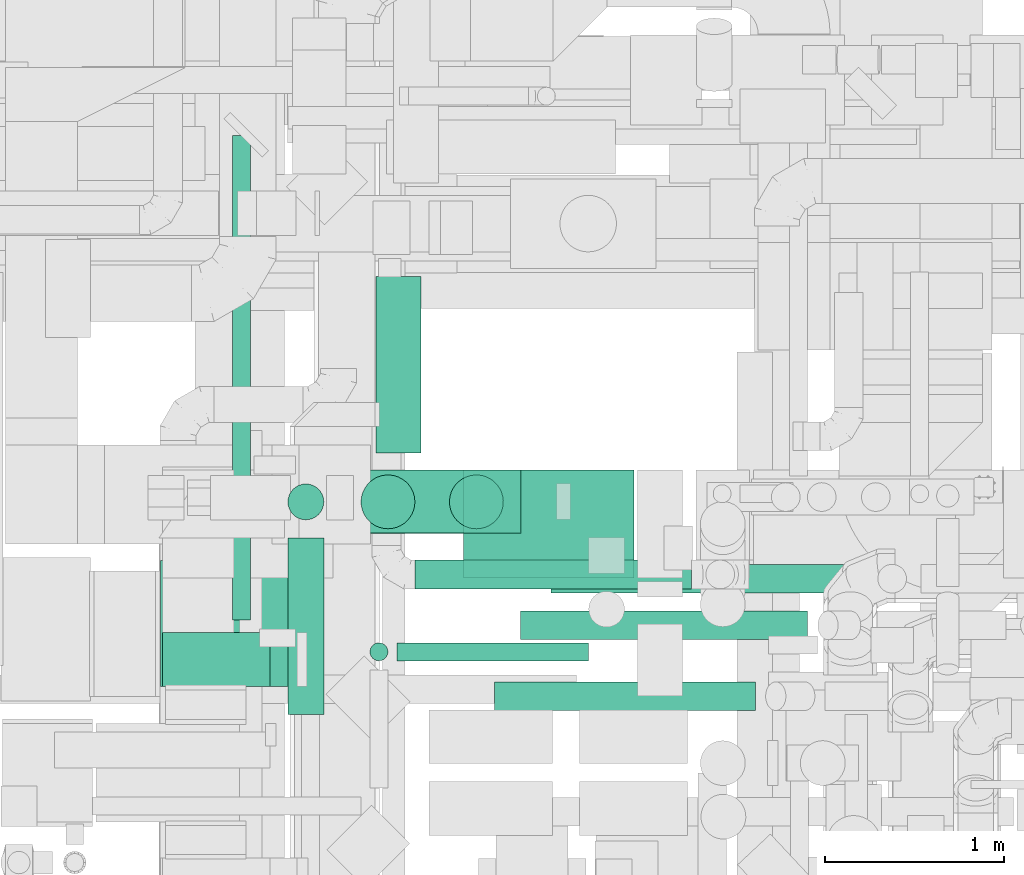
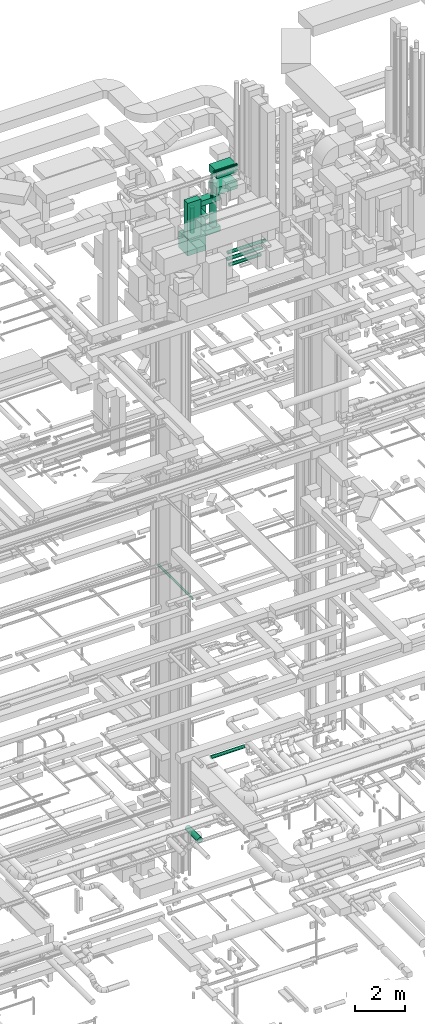
# One storey, part 46 of 337: 18 flow segments.
"""IFC2X3 building model written with IfcOpenShell, lengths in millimetres."""

import ifcopenshell
import ifcopenshell.guid

model = None  # the IFC model being written
_history = None  # IfcOwnerHistory: only IFC2X3 demands one
_inside = {}  # id of a spatial element -> (the spatial element, [elements in it])
_under = {}  # id of a project, library or spatial element -> (it, [spatial elements below it])
_declared = {}  # id of a project -> (the project, [libraries it declares])
_typed = {}  # id of a type object -> (the type object, [elements of that type])
_made_of = {}  # id of a material, layer set ... -> (it, [elements and type objects made of it])


def new_model(schema):
    """Start an empty IFC model of exactly this schema.

    Asked for "IFC4X3", IfcOpenShell would pick the latest addendum, in which some entities
    have other attributes; the version numbers below select the first issue.
    IFC2X3 requires an IfcOwnerHistory on every rooted entity: one is made here for all.
    """
    global model, _history
    if schema == "IFC4X3":
        model = ifcopenshell.file(schema_version=(4, 3, 0, 0))
    else:
        model = ifcopenshell.file(schema=schema)
    _inside.clear()
    _under.clear()
    _declared.clear()
    _typed.clear()
    _made_of.clear()
    _history = None
    if model.schema == "IFC2X3":
        org = make("IfcOrganization", Name="unknown")
        user = make(
            "IfcPersonAndOrganization",
            ThePerson=make("IfcPerson", FamilyName="unknown"),
            TheOrganization=org,
        )
        app = make(
            "IfcApplication",
            ApplicationDeveloper=org,
            Version="unknown",
            ApplicationFullName="unknown",
            ApplicationIdentifier="unknown",
        )
        _history = make(
            "IfcOwnerHistory",
            OwningUser=user,
            OwningApplication=app,
            ChangeAction="ADDED",
            CreationDate=0,
        )
    return model


def make(cls, **values):
    """One entity of the class cls with the attributes given. An attribute that is None is left unset."""
    return model.create_entity(
        cls, **{name: value for name, value in values.items() if value is not None}
    )


def entity(cls, *values):
    """Any entity or typed value of the class cls, its attributes in the order of the schema. None: left unset."""
    e = model.create_entity(cls)
    for i, value in enumerate(values):
        if value is not None:
            e[i] = value
    return e


def rooted(cls, **values):
    """An entity with a GlobalId (a new one), such as an element, a storey or a relation."""
    return make(cls, GlobalId=ifcopenshell.guid.new(), OwnerHistory=_history, **values)


def si_unit(unit_type, name, prefix=None):
    """IfcSIUnit, for example si_unit("LENGTHUNIT", "METRE", prefix="MILLI")."""
    return make("IfcSIUnit", UnitType=unit_type, Prefix=prefix, Name=name)


def converted_unit(unit_type, name, factor, base, dimensions=None, offset=None):
    """IfcConversionBasedUnit, such as the inch: factor (a typed value) times the base unit."""
    return make(
        "IfcConversionBasedUnit"
        if offset is None
        else "IfcConversionBasedUnitWithOffset",
        ConversionOffset=offset,
        Dimensions=None
        if dimensions is None
        else entity("IfcDimensionalExponents", *dimensions),
        UnitType=unit_type,
        Name=name,
        ConversionFactor=make(
            "IfcMeasureWithUnit", ValueComponent=factor, UnitComponent=base
        ),
    )


def derived_unit(unit_type, elements):
    """IfcDerivedUnit: a product of units, each with its exponent."""
    return make(
        "IfcDerivedUnit",
        Elements=[
            make("IfcDerivedUnitElement", Unit=unit, Exponent=power)
            for unit, power in elements
        ],
        UnitType=unit_type,
    )


def assignment(units):
    """IfcUnitAssignment: the units of a project."""
    return None if units is None else make("IfcUnitAssignment", Units=units)


def point(xyz):
    """IfcCartesianPoint."""
    return None if xyz is None else make("IfcCartesianPoint", Coordinates=xyz)


def direction(xyz):
    """IfcDirection."""
    return None if xyz is None else make("IfcDirection", DirectionRatios=xyz)


def frame(location, z_axis=None, x_axis=None):
    """IfcAxis2Placement3D, a coordinate frame: its origin and axes. An axis left out is left unset."""
    return make(
        "IfcAxis2Placement3D",
        Location=point(location),
        Axis=direction(z_axis),
        RefDirection=direction(x_axis),
    )


def frame_2d(location, x_axis=None):
    """IfcAxis2Placement2D, a coordinate frame in the plane: its origin and x axis."""
    return make(
        "IfcAxis2Placement2D", Location=point(location), RefDirection=direction(x_axis)
    )


def origin():
    """The frame at (0, 0, 0) with its axes left unset."""
    return frame((0.0, 0.0, 0.0))


def origin_2d_with_axis():
    """The frame at (0, 0) in the plane with the x axis (1, 0) written out."""
    return frame_2d((0.0, 0.0), x_axis=(1.0, 0.0))


def place(relative_to, where):
    """IfcLocalPlacement: puts the frame where relative to a parent placement (None: the world)."""
    return make(
        "IfcLocalPlacement", PlacementRelTo=relative_to, RelativePlacement=where
    )


def context(
    kind, dimensions, precision=None, world=None, true_north=None, identifier=None
):
    """IfcGeometricRepresentationContext, for example the 3D "Model" context."""
    return make(
        "IfcGeometricRepresentationContext",
        ContextIdentifier=identifier,
        ContextType=kind,
        CoordinateSpaceDimension=dimensions,
        Precision=precision,
        WorldCoordinateSystem=world,
        TrueNorth=true_north,
    )


def subcontext(parent, identifier, kind, view, scale=None):
    """IfcGeometricRepresentationSubContext, for example "Body" below "Model"."""
    return make(
        "IfcGeometricRepresentationSubContext",
        ContextIdentifier=identifier,
        ContextType=kind,
        ParentContext=parent,
        TargetScale=scale,
        TargetView=view,
    )


def project(units=None, contexts=None):
    """IfcProject with its units and contexts."""
    return rooted(
        "IfcProject",
        Name="project",
        RepresentationContexts=contexts,
        UnitsInContext=assignment(units),
    )


def spatial(cls, under=None, at=None, **own):
    """A site, building, storey or space (cls), placed at a placement, below another one or the project."""
    s = rooted(cls, ObjectPlacement=at, **own)
    if under is not None:
        _under.setdefault(under.id(), (under, []))[1].append(s)
    return s


def profile(cls, at=None, kind="AREA", **sizes):
    """A parametric profile (cls). Its sizes go by their IFC names, for example OverallWidth=200.0."""
    return make(cls, ProfileType=kind, Position=at, **sizes)


def rectangle(**sizes):
    """IfcRectangleProfileDef."""
    return profile("IfcRectangleProfileDef", **sizes)


def circle(**sizes):
    """IfcCircleProfileDef."""
    return profile("IfcCircleProfileDef", **sizes)


def extrude(swept, where, along, depth):
    """IfcExtrudedAreaSolid: the profile swept, set in the frame where, extruded along a direction by depth."""
    return make(
        "IfcExtrudedAreaSolid",
        SweptArea=swept,
        Position=where,
        ExtrudedDirection=direction(along),
        Depth=depth,
    )


def shape(context_of_items, identifier, shape_type, items):
    """IfcShapeRepresentation: the items that make up one representation, for example the "Body"."""
    return make(
        "IfcShapeRepresentation",
        ContextOfItems=context_of_items,
        RepresentationIdentifier=identifier,
        RepresentationType=shape_type,
        Items=items,
    )


def made_of(thing, what):
    """Note that an element or type object is made of a material, layer set ...; save() writes the relation."""
    if what is not None:
        _made_of.setdefault(what.id(), (what, []))[1].append(thing)
    return thing


def type_object(cls, material=None, **own):
    """A type object (cls), such as IfcWallType, which elements share."""
    return made_of(rooted(cls, **own), material)


def element(
    cls,
    number,
    at=None,
    inside=None,
    cuts=None,
    type_object=None,
    material=None,
    context=None,
    identifier="Body",
    shape_type=None,
    held_by="IfcProductDefinitionShape",
    body=None,
    shapes=None,
    **own,
):
    """One element of the class cls, such as IfcWall. Its Tag is "e" and its number.

    at: its placement. inside: the storey or other place that contains it. cuts: it is an
    opening in that element (IfcRelVoidsElement). A single representation is given by context,
    identifier, shape_type and body (its items); several are given by shapes. held_by: the class
    of the entity that holds the representations. save() writes the other relations.
    """
    e = rooted(cls, Tag="e%d" % number, ObjectPlacement=at, **own)
    if body is not None:
        shapes = [shape(context, identifier, shape_type, body)]
    if shapes is not None:
        e.Representation = make(held_by, Representations=shapes)
    if inside is not None:
        _inside.setdefault(inside.id(), (inside, []))[1].append(e)
    if cuts is not None:
        rooted(
            "IfcRelVoidsElement", RelatingBuildingElement=cuts, RelatedOpeningElement=e
        )
    if type_object is not None:
        _typed.setdefault(type_object.id(), (type_object, []))[1].append(e)
    return made_of(e, material)


def aggregate(whole, parts):
    """IfcRelAggregates: a whole, such as a stair, and the parts it consists of."""
    return rooted("IfcRelAggregates", RelatingObject=whole, RelatedObjects=parts)


def save(model, path):
    """Write the relations noted so far, then the file.

    IfcRelAggregates (storeys below a building ...), IfcRelContainedInSpatialStructure (elements
    in a storey), IfcRelDefinesByType, IfcRelAssociatesMaterial and IfcRelDeclares: one each for
    every whole, place, type object, material and project.
    """
    for whole, parts in _under.values():
        aggregate(whole, parts)
    for where, things in _inside.values():
        rooted(
            "IfcRelContainedInSpatialStructure",
            RelatedElements=things,
            RelatingStructure=where,
        )
    for kind, things in _typed.values():
        rooted("IfcRelDefinesByType", RelatedObjects=things, RelatingType=kind)
    for what, things in _made_of.values():
        rooted("IfcRelAssociatesMaterial", RelatedObjects=things, RelatingMaterial=what)
    for by, libraries in _declared.values():
        rooted("IfcRelDeclares", RelatingContext=by, RelatedDefinitions=libraries)
    model.write(path)


model = new_model("IFC2X3")

# Units and contexts
model_context = context("Model", 3, precision=0.01, world=origin(), true_north=direction((6.12303176911189e-17, 1.0)))
body_context = subcontext(model_context, "Body", "Model", "MODEL_VIEW")
ifc_project = project(units=[si_unit("LENGTHUNIT", "METRE", prefix="MILLI"), si_unit("AREAUNIT", "SQUARE_METRE"), si_unit("VOLUMEUNIT", "CUBIC_METRE"), converted_unit("PLANEANGLEUNIT", "DEGREE", entity("IfcRatioMeasure", 0.0174532925199433), si_unit("PLANEANGLEUNIT", "RADIAN"), dimensions=[0, 0, 0, 0, 0, 0, 0]), si_unit("MASSUNIT", "GRAM", prefix="KILO"), derived_unit("MASSDENSITYUNIT", [(si_unit("MASSUNIT", "GRAM", prefix="KILO"), 1), (si_unit("LENGTHUNIT", "METRE"), -3)]), derived_unit("MOMENTOFINERTIAUNIT", [(si_unit("LENGTHUNIT", "METRE"), 4)]), si_unit("TIMEUNIT", "SECOND"), si_unit("FREQUENCYUNIT", "HERTZ"), si_unit("THERMODYNAMICTEMPERATUREUNIT", "DEGREE_CELSIUS"), derived_unit("THERMALTRANSMITTANCEUNIT", [(si_unit("MASSUNIT", "GRAM", prefix="KILO"), 1), (si_unit("THERMODYNAMICTEMPERATUREUNIT", "KELVIN"), -1), (si_unit("TIMEUNIT", "SECOND"), -3)]), derived_unit("VOLUMETRICFLOWRATEUNIT", [(si_unit("LENGTHUNIT", "METRE"), 3), (si_unit("TIMEUNIT", "SECOND"), -1)]), derived_unit("MASSFLOWRATEUNIT", [(si_unit("MASSUNIT", "GRAM", prefix="KILO"), 1), (si_unit("TIMEUNIT", "SECOND"), -1)]), derived_unit("ROTATIONALFREQUENCYUNIT", [(si_unit("TIMEUNIT", "SECOND"), -1)]), si_unit("ELECTRICCURRENTUNIT", "AMPERE"), si_unit("ELECTRICVOLTAGEUNIT", "VOLT"), si_unit("POWERUNIT", "WATT"), si_unit("FORCEUNIT", "NEWTON", prefix="KILO"), si_unit("ILLUMINANCEUNIT", "LUX"), si_unit("LUMINOUSFLUXUNIT", "LUMEN"), si_unit("LUMINOUSINTENSITYUNIT", "CANDELA"), derived_unit("USERDEFINED", [(si_unit("MASSUNIT", "GRAM", prefix="KILO"), -1), (si_unit("LENGTHUNIT", "METRE"), -2), (si_unit("TIMEUNIT", "SECOND"), 3), (si_unit("LUMINOUSFLUXUNIT", "LUMEN"), 1)]), derived_unit("LINEARVELOCITYUNIT", [(si_unit("LENGTHUNIT", "METRE"), 1), (si_unit("TIMEUNIT", "SECOND"), -1)]), si_unit("PRESSUREUNIT", "PASCAL"), derived_unit("USERDEFINED", [(si_unit("LENGTHUNIT", "METRE"), -2), (si_unit("MASSUNIT", "GRAM", prefix="KILO"), 1), (si_unit("TIMEUNIT", "SECOND"), -2)]), derived_unit("LINEARFORCEUNIT", [(si_unit("MASSUNIT", "GRAM", prefix="KILO"), 1), (si_unit("LENGTHUNIT", "METRE"), 1), (si_unit("TIMEUNIT", "SECOND"), -2), (si_unit("LENGTHUNIT", "METRE"), -1)]), derived_unit("PLANARFORCEUNIT", [(si_unit("MASSUNIT", "GRAM", prefix="KILO"), 1), (si_unit("LENGTHUNIT", "METRE"), 1), (si_unit("TIMEUNIT", "SECOND"), -2), (si_unit("LENGTHUNIT", "METRE"), -2)])], contexts=[model_context])

# Site, building, storey
site_placement = place(None, origin())
site = spatial("IfcSite", under=ifc_project, at=site_placement, CompositionType="ELEMENT")
building_placement = place(site_placement, origin())
building = spatial("IfcBuilding", under=site, at=building_placement, CompositionType="ELEMENT")
storey_placement = place(building_placement, origin())
storey = spatial("IfcBuildingStorey", under=building, at=storey_placement, CompositionType="ELEMENT", Elevation=0.0)

# Flow segments
duct_segment_type_1 = type_object("IfcDuctSegmentType", PredefinedType="NOTDEFINED")
flow_segment_1_placement = place(storey_placement, frame((46892.82, 12824.59, 29900.0)))
element("IfcFlowSegment", 1, at=flow_segment_1_placement, inside=storey, type_object=duct_segment_type_1, context=body_context, shape_type="SweptSolid", body=[
    extrude(rectangle(XDim=996.999999999999, YDim=350.000000000001, at=origin_2d_with_axis()), frame((498.5, 175.0, 0.0)), (0.0, 0.0, 1.0), 250.000000000004),
])
flow_segment_2_placement = place(storey_placement, frame((46491.97, 12823.12, 28400.0)))
element("IfcFlowSegment", 2, at=flow_segment_2_placement, inside=storey, type_object=duct_segment_type_1, context=body_context, shape_type="SweptSolid", body=[
    extrude(rectangle(XDim=1400.0, YDim=350.000000000001, at=origin_2d_with_axis()), frame((700.0, 175.0, 0.0)), (0.0, 0.0, 1.0), 250.000000000004),
])
flow_segment_3_placement = place(storey_placement, frame((45895.05, 11970.6, 29220.0)))
element("IfcFlowSegment", 3, at=flow_segment_3_placement, inside=storey, type_object=duct_segment_type_1, context=body_context, shape_type="SweptSolid", body=[
    extrude(rectangle(XDim=300.000000000001, YDim=600.000000000002, at=origin_2d_with_axis()), frame((300.0, 150.0, 0.0), z_axis=(0.0, 0.0, 1.0), x_axis=(0.0, 1.0, 0.0)), (0.0, 0.0, 1.0), 1729.99999999995),
])
flow_segment_4_placement = place(storey_placement, frame((45884.94, 11970.6, 28400.0)))
element("IfcFlowSegment", 4, at=flow_segment_4_placement, inside=storey, type_object=duct_segment_type_1, context=body_context, shape_type="SweptSolid", body=[
    extrude(rectangle(XDim=840.0, YDim=699.999999999999, at=origin_2d_with_axis()), frame((420.0, 350.0, 0.0), z_axis=(0.0, 0.0, 1.0), x_axis=(-1.0, 0.0, 0.0)), (0.0, 0.0, 1.0), 800.0),
])
flow_segment_5_placement = place(storey_placement, frame((47571.48, 12574.75, 30395.0)))
element("IfcFlowSegment", 5, at=flow_segment_5_placement, inside=storey, type_object=duct_segment_type_1, context=body_context, shape_type="SweptSolid", body=[
    extrude(rectangle(XDim=950.563083200115, YDim=600.0, at=origin_2d_with_axis()), frame((475.28, 300.0, 0.0)), (0.0, 0.0, 1.0), 349.999999999998),
])
flow_segment_6_placement = place(storey_placement, frame((47571.48, 12574.75, 31195.0)))
element("IfcFlowSegment", 6, at=flow_segment_6_placement, inside=storey, type_object=duct_segment_type_1, context=body_context, shape_type="SweptSolid", body=[
    extrude(rectangle(XDim=950.563083200124, YDim=600.0, at=origin_2d_with_axis()), frame((475.28, 300.0, 0.0)), (0.0, 0.0, 1.0), 349.999999999998),
])
duct_segment_type_2 = type_object("IfcDuctSegmentType", PredefinedType="NOTDEFINED")
flow_segment_7_placement = place(storey_placement, frame((47083.99, 13270.83, -1226.6)))
element("IfcFlowSegment", 7, at=flow_segment_7_placement, inside=storey, type_object=duct_segment_type_2, context=body_context, shape_type="SweptSolid", body=[
    extrude(circle(Radius=125.0, at=origin_2d_with_axis()), frame((126.6, 0.0, 126.6), z_axis=(0.0, 1.0, 0.0), x_axis=(1.0, 0.0, 0.0)), (0.0, 0.0, 1.0), 982.562899999989),
])
flow_segment_8_placement = place(storey_placement, frame((46284.07, 12340.55, 11398.4)))
element("IfcFlowSegment", 8, at=flow_segment_8_placement, inside=storey, type_object=duct_segment_type_2, context=body_context, shape_type="SweptSolid", body=[
    extrude(circle(Radius=50.0, at=origin_2d_with_axis()), frame((51.6, 0.0, 51.6), z_axis=(0.0, 1.0, 0.0), x_axis=(-1.0, 0.0, 0.0)), (0.0, 0.0, 1.0), 2697.74064838761),
])
flow_segment_9_placement = place(storey_placement, frame((47890.35, 12228.45, 27278.4)))
element("IfcFlowSegment", 9, at=flow_segment_9_placement, inside=storey, type_object=duct_segment_type_2, context=body_context, shape_type="SweptSolid", body=[
    extrude(circle(Radius=80.0, at=origin_2d_with_axis()), frame((0.0, 81.6, 81.6), z_axis=(1.0, 0.0, 0.0), x_axis=(0.0, 1.0, 0.0)), (0.0, 0.0, 1.0), 1600.0),
])
flow_segment_10_placement = place(storey_placement, frame((47746.53, 11833.6, 27288.4)))
element("IfcFlowSegment", 10, at=flow_segment_10_placement, inside=storey, type_object=duct_segment_type_2, context=body_context, shape_type="SweptSolid", body=[
    extrude(circle(Radius=80.0, at=origin_2d_with_axis()), frame((0.0, 81.6, 81.6), z_axis=(1.0, 0.0, 0.0), x_axis=(0.0, 1.0, 0.0)), (0.0, 0.0, 1.0), 1452.99112382781),
])
flow_segment_11_placement = place(storey_placement, frame((48061.09, 12488.5, 27368.4)))
element("IfcFlowSegment", 11, at=flow_segment_11_placement, inside=storey, type_object=duct_segment_type_2, context=body_context, shape_type="SweptSolid", body=[
    extrude(circle(Radius=80.0, at=origin_2d_with_axis()), frame((0.0, 81.6, 81.6), z_axis=(1.0, 0.0, 0.0), x_axis=(0.0, 1.0, 0.0)), (0.0, 0.0, 1.0), 1740.00000000001),
])
for number, where in (
    (12, (47492.88, 12846.53, 28670.0)),
    (13, (47000.38, 12846.53, 28670.0)),
):
    element("IfcFlowSegment", number, at=place(storey_placement, frame(where)), inside=storey, type_object=duct_segment_type_2, context=body_context, shape_type="SweptSolid", body=[
        extrude(circle(Radius=150.0, at=origin_2d_with_axis()), frame((151.6, 151.6, 0.0), z_axis=(0.0, 0.0, 1.0), x_axis=(0.0, -1.0, 0.0)), (0.0, 0.0, 1.0), 1209.99999999997),
    ])
flow_segment_12_placement = place(storey_placement, frame((46592.88, 12896.53, 28670.0)))
element("IfcFlowSegment", 14, at=flow_segment_12_placement, inside=storey, type_object=duct_segment_type_2, context=body_context, shape_type="SweptSolid", body=[
    extrude(circle(Radius=100.0, at=origin_2d_with_axis()), frame((101.6, 101.6, 0.0), z_axis=(0.0, 0.0, 1.0), x_axis=(0.0, 1.0, 0.0)), (0.0, 0.0, 1.0), 1230.0),
])
flow_segment_13_placement = place(storey_placement, frame((47201.64, 12111.15, 31851.83)))
element("IfcFlowSegment", 15, at=flow_segment_13_placement, inside=storey, type_object=duct_segment_type_2, context=body_context, shape_type="SweptSolid", body=[
    extrude(circle(Radius=50.0, at=origin_2d_with_axis()), frame((0.0, 51.6, 51.6), z_axis=(1.0, 0.0, 0.0), x_axis=(0.0, 1.0, 0.0)), (0.0, 0.0, 1.0), 1068.46397926371),
])
flow_segment_14_placement = place(storey_placement, frame((47050.05, 12111.15, 30703.42)))
element("IfcFlowSegment", 16, at=flow_segment_14_placement, inside=storey, type_object=duct_segment_type_2, context=body_context, shape_type="SweptSolid", body=[
    extrude(circle(Radius=50.0, at=origin_2d_with_axis()), frame((51.6, 51.6, 0.0), z_axis=(0.0, 0.0, 1.0), x_axis=(0.0, -1.0, 0.0)), (0.0, 0.0, 1.0), 1100.00000000001),
])
flow_segment_15_placement = place(storey_placement, frame((46592.88, 11814.6, 29998.4)))
element("IfcFlowSegment", 17, at=flow_segment_15_placement, inside=storey, type_object=duct_segment_type_2, context=body_context, shape_type="SweptSolid", body=[
    extrude(circle(Radius=100.0, at=origin_2d_with_axis()), frame((101.6, 0.0, 101.6), z_axis=(0.0, 1.0, 0.0), x_axis=(1.0, 0.0, 0.0)), (0.0, 0.0, 1.0), 983.52055788052),
])
flow_segment_16_placement = place(storey_placement, frame((47303.34, 12512.32, 3198.4)))
element("IfcFlowSegment", 18, at=flow_segment_16_placement, inside=storey, type_object=duct_segment_type_2, context=body_context, shape_type="SweptSolid", body=[
    extrude(circle(Radius=80.0, at=origin_2d_with_axis()), frame((0.0, 81.6, 81.6), z_axis=(1.0, 0.0, 0.0), x_axis=(0.0, -1.0, 0.0)), (0.0, 0.0, 1.0), 1540.00000000004),
])

save(model, "model.ifc")
